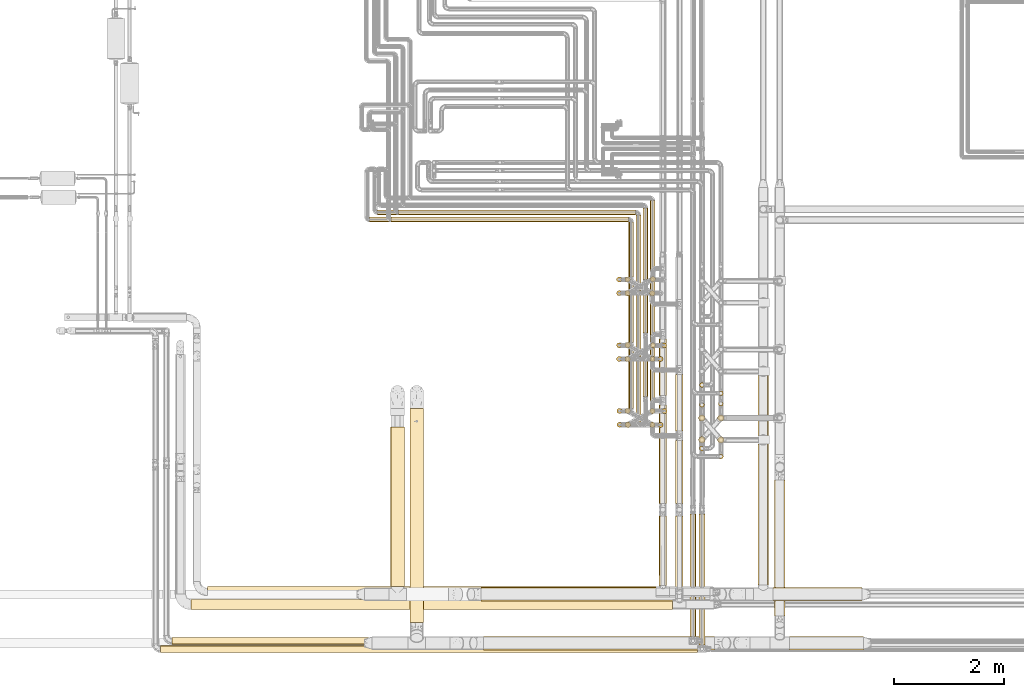
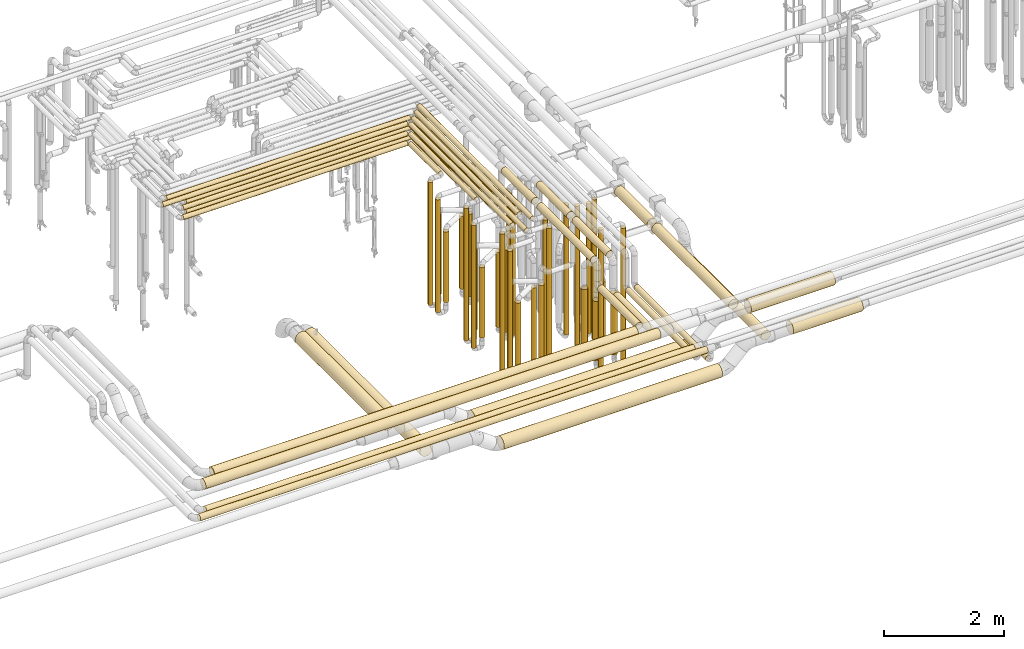
# One storey, part 4 of 827: 71 coverings.
"""IFC2X3 building model written with IfcOpenShell, lengths in millimetres."""

from ifc_helpers import new_model, entity, si_unit, converted_unit, derived_unit, direction, frame, origin, origin_2d_with_axis, place, context, subcontext, project, spatial, circle, extrude, element, save


model = new_model("IFC2X3")

# Units and contexts
model_context = context("Model", 3, precision=0.01, world=origin(), true_north=direction((6.12303176911189e-17, 1.0)))
body_context = subcontext(model_context, "Body", "Model", "MODEL_VIEW")
ifc_project = project(units=[si_unit("LENGTHUNIT", "METRE", prefix="MILLI"), si_unit("AREAUNIT", "SQUARE_METRE"), si_unit("VOLUMEUNIT", "CUBIC_METRE"), converted_unit("PLANEANGLEUNIT", "DEGREE", entity("IfcRatioMeasure", 0.0174532925199433), si_unit("PLANEANGLEUNIT", "RADIAN"), dimensions=[0, 0, 0, 0, 0, 0, 0]), si_unit("MASSUNIT", "GRAM", prefix="KILO"), derived_unit("MASSDENSITYUNIT", [(si_unit("MASSUNIT", "GRAM", prefix="KILO"), 1), (si_unit("LENGTHUNIT", "METRE"), -3)]), derived_unit("MOMENTOFINERTIAUNIT", [(si_unit("LENGTHUNIT", "METRE"), 4)]), si_unit("TIMEUNIT", "SECOND"), si_unit("FREQUENCYUNIT", "HERTZ"), si_unit("THERMODYNAMICTEMPERATUREUNIT", "DEGREE_CELSIUS"), derived_unit("THERMALTRANSMITTANCEUNIT", [(si_unit("MASSUNIT", "GRAM", prefix="KILO"), 1), (si_unit("THERMODYNAMICTEMPERATUREUNIT", "KELVIN"), -1), (si_unit("TIMEUNIT", "SECOND"), -3)]), derived_unit("VOLUMETRICFLOWRATEUNIT", [(si_unit("LENGTHUNIT", "METRE"), 3), (si_unit("TIMEUNIT", "SECOND"), -1)]), derived_unit("MASSFLOWRATEUNIT", [(si_unit("MASSUNIT", "GRAM", prefix="KILO"), 1), (si_unit("TIMEUNIT", "SECOND"), -1)]), derived_unit("ROTATIONALFREQUENCYUNIT", [(si_unit("TIMEUNIT", "SECOND"), -1)]), si_unit("ELECTRICCURRENTUNIT", "AMPERE"), si_unit("ELECTRICVOLTAGEUNIT", "VOLT"), si_unit("POWERUNIT", "WATT"), si_unit("FORCEUNIT", "NEWTON", prefix="KILO"), si_unit("ILLUMINANCEUNIT", "LUX"), si_unit("LUMINOUSFLUXUNIT", "LUMEN"), si_unit("LUMINOUSINTENSITYUNIT", "CANDELA"), derived_unit("USERDEFINED", [(si_unit("MASSUNIT", "GRAM", prefix="KILO"), -1), (si_unit("LENGTHUNIT", "METRE"), -2), (si_unit("TIMEUNIT", "SECOND"), 3), (si_unit("LUMINOUSFLUXUNIT", "LUMEN"), 1)]), derived_unit("LINEARVELOCITYUNIT", [(si_unit("LENGTHUNIT", "METRE"), 1), (si_unit("TIMEUNIT", "SECOND"), -1)]), si_unit("PRESSUREUNIT", "PASCAL"), derived_unit("USERDEFINED", [(si_unit("LENGTHUNIT", "METRE"), -2), (si_unit("MASSUNIT", "GRAM", prefix="KILO"), 1), (si_unit("TIMEUNIT", "SECOND"), -2)]), derived_unit("LINEARFORCEUNIT", [(si_unit("MASSUNIT", "GRAM", prefix="KILO"), 1), (si_unit("LENGTHUNIT", "METRE"), 1), (si_unit("TIMEUNIT", "SECOND"), -2), (si_unit("LENGTHUNIT", "METRE"), -1)]), derived_unit("PLANARFORCEUNIT", [(si_unit("MASSUNIT", "GRAM", prefix="KILO"), 1), (si_unit("LENGTHUNIT", "METRE"), 1), (si_unit("TIMEUNIT", "SECOND"), -2), (si_unit("LENGTHUNIT", "METRE"), -2)])], contexts=[model_context])

# Site, building, storey
site_placement = place(None, origin())
site = spatial("IfcSite", under=ifc_project, at=site_placement, CompositionType="ELEMENT")
building_placement = place(site_placement, origin())
building = spatial("IfcBuilding", under=site, at=building_placement, CompositionType="ELEMENT")
storey_placement = place(building_placement, frame((0.0, 0.0, 28200.0)))
storey = spatial("IfcBuildingStorey", under=building, at=storey_placement, Name="08", CompositionType="ELEMENT", Elevation=28200.0)

# Coverings
covering_1_placement = place(storey_placement, frame((35072.29, 11508.46, 448.0)))
element("IfcCovering", 1, at=covering_1_placement, inside=storey, Name=":ADSK_", ObjectType=":ADSK_", PredefinedType="INSULATION", context=body_context, shape_type="SweptSolid", body=[
    extrude(circle(Radius=46.15, at=origin_2d_with_axis()), frame((47.75, 47.75, 0.0), z_axis=(0.0, 0.0, 1.0), x_axis=(0.0, -1.0, 0.0)), (0.0, 0.0, 1.0), 2504.00000000002),
])
covering_2_placement = place(storey_placement, frame((35895.3, 11758.46, 448.0)))
element("IfcCovering", 2, at=covering_2_placement, inside=storey, Name=":ADSK_", ObjectType=":ADSK_", PredefinedType="INSULATION", context=body_context, shape_type="SweptSolid", body=[
    extrude(circle(Radius=46.15, at=origin_2d_with_axis()), frame((47.75, 47.75, 0.0)), (0.0, 0.0, 1.0), 2704.00000000003),
])
covering_3_placement = place(storey_placement, frame((35077.29, 10309.34, 448.0)))
element("IfcCovering", 3, at=covering_3_placement, inside=storey, Name=":ADSK_", ObjectType=":ADSK_", PredefinedType="INSULATION", context=body_context, shape_type="SweptSolid", body=[
    extrude(circle(Radius=46.15, at=origin_2d_with_axis()), frame((47.75, 47.75, 0.0), z_axis=(0.0, 0.0, 1.0), x_axis=(0.0, -1.0, 0.0)), (0.0, 0.0, 1.0), 2704.00000000001),
])
covering_4_placement = place(storey_placement, frame((35900.3, 10558.46, 448.0)))
element("IfcCovering", 4, at=covering_4_placement, inside=storey, Name=":ADSK_", ObjectType=":ADSK_", PredefinedType="INSULATION", context=body_context, shape_type="SweptSolid", body=[
    extrude(circle(Radius=46.15, at=origin_2d_with_axis()), frame((47.75, 47.75, 0.0), z_axis=(0.0, 0.0, 1.0), x_axis=(-1.0, 0.0, 0.0)), (0.0, 0.0, 1.0), 2904.00000000001),
])
covering_5_placement = place(storey_placement, frame((35847.22, 8921.39, 3479.16)))
element("IfcCovering", 5, at=covering_5_placement, inside=storey, Name=":ADSK_", ObjectType=":ADSK_", PredefinedType="INSULATION", context=body_context, shape_type="SweptSolid", body=[
    extrude(circle(Radius=69.25, at=origin_2d_with_axis()), frame((70.85, 0.0, 70.85), z_axis=(0.0, 1.0, -9.11558874934062e-08), x_axis=(1.0, 0.0, 0.0)), (0.0, 0.0, 1.0), 1798.81487069227),
])
covering_6_placement = place(storey_placement, frame((35847.2, 7422.68, 3029.15)))
element("IfcCovering", 6, at=covering_6_placement, inside=storey, Name=":ADSK_", ObjectType=":ADSK_", PredefinedType="INSULATION", context=body_context, shape_type="SweptSolid", body=[
    extrude(circle(Radius=69.25, at=origin_2d_with_axis()), frame((70.85, 1270.71, 70.85), z_axis=(0.000807635041357438, -0.999999673862767, 0.0), x_axis=(0.999999673862767, 0.000807635041357438, 0.0)), (0.0, 0.0, 1.0), 1270.65564093337),
])
covering_7_placement = place(storey_placement, frame((35682.29, 11854.2, 3152.25)))
element("IfcCovering", 7, at=covering_7_placement, inside=storey, Name=":ADSK_", ObjectType=":ADSK_", PredefinedType="INSULATION", context=body_context, shape_type="SweptSolid", body=[
    extrude(circle(Radius=46.15, at=origin_2d_with_axis()), frame((47.75, 0.0, 47.75), z_axis=(0.0, 1.0, 0.0), x_axis=(-1.0, 0.0, 0.0)), (0.0, 0.0, 1.0), 2587.79707398043),
])
covering_8_placement = place(storey_placement, frame((35552.35, 12031.2, 3152.25)))
element("IfcCovering", 8, at=covering_8_placement, inside=storey, Name=":ADSK_", ObjectType=":ADSK_", PredefinedType="INSULATION", context=body_context, shape_type="SweptSolid", body=[
    extrude(circle(Radius=46.15, at=origin_2d_with_axis()), frame((47.75, 0.0, 47.75), z_axis=(0.0, 1.0, 0.0), x_axis=(1.0, 0.0, 0.0)), (0.0, 0.0, 1.0), 2280.79727405418),
])
covering_9_placement = place(storey_placement, frame((35682.29, 10654.2, 3352.25)))
element("IfcCovering", 9, at=covering_9_placement, inside=storey, Name=":ADSK_", ObjectType=":ADSK_", PredefinedType="INSULATION", context=body_context, shape_type="SweptSolid", body=[
    extrude(circle(Radius=46.15, at=origin_2d_with_axis()), frame((47.75, 0.0, 47.75), z_axis=(0.0, 1.0, 0.0), x_axis=(1.0, 0.0, 0.0)), (0.0, 0.0, 1.0), 3787.79707398042),
])
covering_10_placement = place(storey_placement, frame((35552.35, 10876.38, 3352.25)))
element("IfcCovering", 10, at=covering_10_placement, inside=storey, Name=":ADSK_", ObjectType=":ADSK_", PredefinedType="INSULATION", context=body_context, shape_type="SweptSolid", body=[
    extrude(circle(Radius=46.15, at=origin_2d_with_axis()), frame((47.75, 0.0, 47.75), z_axis=(0.0, 1.0, 0.0), x_axis=(1.0, 0.0, 0.0)), (0.0, 0.0, 1.0), 3435.62396825438),
])
covering_11_placement = place(storey_placement, frame((35847.22, 10892.2, 3479.16)))
element("IfcCovering", 11, at=covering_11_placement, inside=storey, Name=":ADSK_", ObjectType=":ADSK_", PredefinedType="INSULATION", context=body_context, shape_type="SweptSolid", body=[
    extrude(circle(Radius=69.25, at=origin_2d_with_axis()), frame((70.85, 0.0, 70.85), z_axis=(0.0, 1.0, -9.11558935474048e-08), x_axis=(1.0, 0.0, 0.0)), (0.0, 0.0, 1.0), 1027.87693556046),
])
covering_12_placement = place(storey_placement, frame((35228.27, 10306.49, 604.0)))
element("IfcCovering", 12, at=covering_12_placement, inside=storey, Name=":ADSK_", ObjectType=":ADSK_", PredefinedType="INSULATION", context=body_context, shape_type="SweptSolid", body=[
    extrude(circle(Radius=49.0, at=origin_2d_with_axis()), frame((50.6, 50.6, 0.0), z_axis=(0.0, 1.97430995600526e-06, 1.0), x_axis=(-1.0, 0.0, 0.0)), (0.0, 0.0, 1.0), 1439.00000000281),
])
covering_13_placement = place(storey_placement, frame((35677.45, 10555.61, 559.0)))
element("IfcCovering", 13, at=covering_13_placement, inside=storey, Name=":ADSK_", ObjectType=":ADSK_", PredefinedType="INSULATION", context=body_context, shape_type="SweptSolid", body=[
    extrude(circle(Radius=49.0, at=origin_2d_with_axis()), frame((50.6, 50.6, 0.0), z_axis=(0.0, 0.0, 1.0), x_axis=(-1.0, 0.0, 0.0)), (0.0, 0.0, 1.0), 1484.0),
])
covering_14_placement = place(storey_placement, frame((35224.44, 11505.05, 603.98)))
element("IfcCovering", 14, at=covering_14_placement, inside=storey, Name=":ADSK_", ObjectType=":ADSK_", PredefinedType="INSULATION", context=body_context, shape_type="SweptSolid", body=[
    extrude(circle(Radius=49.0, at=origin_2d_with_axis()), frame((50.6, 51.21, 0.02), z_axis=(0.0, -0.000429537009763512, 0.999999907748974), x_axis=(1.0, 0.0, 0.0)), (0.0, 0.0, 1.0), 1438.97359676792),
])
covering_15_placement = place(storey_placement, frame((35686.26, 11755.07, 511.98)))
element("IfcCovering", 15, at=covering_15_placement, inside=storey, Name=":ADSK_", ObjectType=":ADSK_", PredefinedType="INSULATION", context=body_context, shape_type="SweptSolid", body=[
    extrude(circle(Radius=49.0, at=origin_2d_with_axis()), frame((50.6, 51.09, 0.02), z_axis=(0.0, -0.000321811119658756, 0.9999999482188), x_axis=(1.0, 0.0, 0.0)), (0.0, 0.0, 1.0), 1531.00008703173),
])
covering_16_placement = place(storey_placement, frame((27310.33, 6983.4, 3003.4)))
element("IfcCovering", 16, at=covering_16_placement, inside=storey, Name=":ADSK_", ObjectType=":ADSK_", PredefinedType="INSULATION", context=body_context, shape_type="SweptSolid", body=[
    extrude(circle(Radius=95.0, at=origin_2d_with_axis()), frame((0.0, 96.6, 96.6), z_axis=(1.0, 0.0, 0.0), x_axis=(0.0, -0.707106781186544, -0.707106781186551)), (0.0, 0.0, 1.0), 8785.70070250989),
])
covering_17_placement = place(storey_placement, frame((31094.52, 14182.26, 3152.25)))
element("IfcCovering", 17, at=covering_17_placement, inside=storey, Name=":ADSK_", ObjectType=":ADSK_", PredefinedType="INSULATION", context=body_context, shape_type="SweptSolid", body=[
    extrude(circle(Radius=46.15, at=origin_2d_with_axis()), frame((0.0, 47.75, 47.75), z_axis=(1.0, 0.0, 0.0), x_axis=(0.0, -1.0, 0.0)), (0.0, 0.0, 1.0), 4327.51165000006),
])
covering_18_placement = place(storey_placement, frame((30964.52, 14052.26, 3152.25)))
element("IfcCovering", 18, at=covering_18_placement, inside=storey, Name=":ADSK_", ObjectType=":ADSK_", PredefinedType="INSULATION", context=body_context, shape_type="SweptSolid", body=[
    extrude(circle(Radius=46.15, at=origin_2d_with_axis()), frame((0.0, 47.75, 47.75), z_axis=(1.0, 0.0, 0.0), x_axis=(0.0, -1.0, 0.0)), (0.0, 0.0, 1.0), 4327.51165000005),
])
covering_19_placement = place(storey_placement, frame((30718.34, 14182.26, 3352.25)))
element("IfcCovering", 19, at=covering_19_placement, inside=storey, Name=":ADSK_", ObjectType=":ADSK_", PredefinedType="INSULATION", context=body_context, shape_type="SweptSolid", body=[
    extrude(circle(Radius=46.15, at=origin_2d_with_axis()), frame((0.0, 47.75, 47.75), z_axis=(1.0, 0.0, 0.0), x_axis=(0.0, -1.0, 0.0)), (0.0, 0.0, 1.0), 4703.69587000002),
])
covering_20_placement = place(storey_placement, frame((30569.52, 14052.26, 3352.25)))
element("IfcCovering", 20, at=covering_20_placement, inside=storey, Name=":ADSK_", ObjectType=":ADSK_", PredefinedType="INSULATION", context=body_context, shape_type="SweptSolid", body=[
    extrude(circle(Radius=46.15, at=origin_2d_with_axis()), frame((0.0, 47.75, 47.75), z_axis=(1.0, 0.0, 0.0), x_axis=(0.0, -1.0, 0.0)), (0.0, 0.0, 1.0), 4722.51165000002),
])
covering_21_placement = place(storey_placement, frame((35072.29, 11758.46, 448.0)))
element("IfcCovering", 21, at=covering_21_placement, inside=storey, Name=":ADSK_", ObjectType=":ADSK_", PredefinedType="INSULATION", context=body_context, shape_type="SweptSolid", body=[
    extrude(circle(Radius=46.15, at=origin_2d_with_axis()), frame((47.75, 47.75, 0.0), z_axis=(0.0, 0.0, 1.0), x_axis=(0.0, -1.0, 0.0)), (0.0, 0.0, 1.0), 2704.00000000002),
])
covering_22_placement = place(storey_placement, frame((35826.04, 11508.42, 448.0)))
element("IfcCovering", 22, at=covering_22_placement, inside=storey, Name=":ADSK_", ObjectType=":ADSK_", PredefinedType="INSULATION", context=body_context, shape_type="SweptSolid", body=[
    extrude(circle(Radius=46.15, at=origin_2d_with_axis()), frame((47.75, 47.75, 0.0), z_axis=(0.0, 0.0, 1.0), x_axis=(-1.0, 0.0, 0.0)), (0.0, 0.0, 1.0), 2704.00000000003),
])
covering_23_placement = place(storey_placement, frame((35077.29, 10561.4, 448.0)))
element("IfcCovering", 23, at=covering_23_placement, inside=storey, Name=":ADSK_", ObjectType=":ADSK_", PredefinedType="INSULATION", context=body_context, shape_type="SweptSolid", body=[
    extrude(circle(Radius=46.15, at=origin_2d_with_axis()), frame((47.75, 47.75, 0.0), z_axis=(0.0, 0.0, 1.0), x_axis=(0.0, -1.0, 0.0)), (0.0, 0.0, 1.0), 2904.0),
])
covering_24_placement = place(storey_placement, frame((35831.04, 10308.42, 448.0)))
element("IfcCovering", 24, at=covering_24_placement, inside=storey, Name=":ADSK_", ObjectType=":ADSK_", PredefinedType="INSULATION", context=body_context, shape_type="SweptSolid", body=[
    extrude(circle(Radius=46.15, at=origin_2d_with_axis()), frame((47.75, 47.75, 0.0)), (0.0, 0.0, 1.0), 2904.00000000001),
])
covering_25_placement = place(storey_placement, frame((36149.19, 8921.39, 3479.16)))
element("IfcCovering", 25, at=covering_25_placement, inside=storey, Name=":ADSK_", ObjectType=":ADSK_", PredefinedType="INSULATION", context=body_context, shape_type="SweptSolid", body=[
    extrude(circle(Radius=69.25, at=origin_2d_with_axis()), frame((70.85, 0.0, 70.85), z_axis=(0.0, 1.0, -8.51254598960259e-08), x_axis=(1.0, 0.0, 0.0)), (0.0, 0.0, 1.0), 1148.81413940413),
])
covering_26_placement = place(storey_placement, frame((36149.19, 7376.95, 2779.15)))
element("IfcCovering", 26, at=covering_26_placement, inside=storey, Name=":ADSK_", ObjectType=":ADSK_", PredefinedType="INSULATION", context=body_context, shape_type="SweptSolid", body=[
    extrude(circle(Radius=69.25, at=origin_2d_with_axis()), frame((70.85, 0.0, 70.85), z_axis=(0.0, 1.0, 0.0), x_axis=(1.0, 0.0, 0.0)), (0.0, 0.0, 1.0), 1316.44024231723),
])
covering_27_placement = place(storey_placement, frame((35292.29, 11854.2, 3152.25)))
element("IfcCovering", 27, at=covering_27_placement, inside=storey, Name=":ADSK_", ObjectType=":ADSK_", PredefinedType="INSULATION", context=body_context, shape_type="SweptSolid", body=[
    extrude(circle(Radius=46.15, at=origin_2d_with_axis()), frame((47.75, 0.0, 47.75), z_axis=(0.0, 1.0, 0.0), x_axis=(-1.0, 0.0, 0.0)), (0.0, 0.0, 1.0), 2197.79707405417),
])
covering_28_placement = place(storey_placement, frame((35422.29, 11604.17, 3152.25)))
element("IfcCovering", 28, at=covering_28_placement, inside=storey, Name=":ADSK_", ObjectType=":ADSK_", PredefinedType="INSULATION", context=body_context, shape_type="SweptSolid", body=[
    extrude(circle(Radius=46.15, at=origin_2d_with_axis()), frame((47.75, 0.0, 47.75), z_axis=(0.0, 1.0, 0.0), x_axis=(-1.0, 0.0, 0.0)), (0.0, 0.0, 1.0), 2577.83166077068),
])
covering_29_placement = place(storey_placement, frame((35292.29, 10657.14, 3352.25)))
element("IfcCovering", 29, at=covering_29_placement, inside=storey, Name=":ADSK_", ObjectType=":ADSK_", PredefinedType="INSULATION", context=body_context, shape_type="SweptSolid", body=[
    extrude(circle(Radius=46.15, at=origin_2d_with_axis()), frame((47.75, 0.0, 47.75), z_axis=(0.0, 1.0, 0.0), x_axis=(-1.0, 0.0, 0.0)), (0.0, 0.0, 1.0), 3394.85688841738),
])
covering_30_placement = place(storey_placement, frame((35422.29, 10404.17, 3352.25)))
element("IfcCovering", 30, at=covering_30_placement, inside=storey, Name=":ADSK_", ObjectType=":ADSK_", PredefinedType="INSULATION", context=body_context, shape_type="SweptSolid", body=[
    extrude(circle(Radius=46.15, at=origin_2d_with_axis()), frame((47.75, 0.0, 47.75), z_axis=(0.0, 1.0, 0.0), x_axis=(1.0, 0.0, 0.0)), (0.0, 0.0, 1.0), 3777.83166077068),
])
covering_31_placement = place(storey_placement, frame((36149.19, 10242.2, 3479.15)))
element("IfcCovering", 31, at=covering_31_placement, inside=storey, Name=":ADSK_", ObjectType=":ADSK_", PredefinedType="INSULATION", context=body_context, shape_type="SweptSolid", body=[
    extrude(circle(Radius=69.25, at=origin_2d_with_axis()), frame((70.85, 0.0, 70.85), z_axis=(0.0, 1.0, -9.11558977614012e-08), x_axis=(1.0, 0.0, 0.0)), (0.0, 0.0, 1.0), 1027.87693556044),
])
covering_32_placement = place(storey_placement, frame((35677.45, 10305.57, 559.0)))
element("IfcCovering", 32, at=covering_32_placement, inside=storey, Name=":ADSK_", ObjectType=":ADSK_", PredefinedType="INSULATION", context=body_context, shape_type="SweptSolid", body=[
    extrude(circle(Radius=49.0, at=origin_2d_with_axis()), frame((50.6, 50.6, 0.0), z_axis=(0.0, 0.0, 1.0), x_axis=(-1.0, 0.0, 0.0)), (0.0, 0.0, 1.0), 1688.99999999998),
])
covering_33_placement = place(storey_placement, frame((35226.14, 10558.53, 604.0)))
element("IfcCovering", 33, at=covering_33_placement, inside=storey, Name=":ADSK_", ObjectType=":ADSK_", PredefinedType="INSULATION", context=body_context, shape_type="SweptSolid", body=[
    extrude(circle(Radius=49.0, at=origin_2d_with_axis()), frame((50.6, 50.61, 0.0), z_axis=(0.0, -1.10407019482887e-05, 1.0), x_axis=(-1.0, 0.0, 0.0)), (0.0, 0.0, 1.0), 1644.00000010021),
])
covering_34_placement = place(storey_placement, frame((35678.19, 11503.87, 558.95)))
element("IfcCovering", 34, at=covering_34_placement, inside=storey, Name=":ADSK_", ObjectType=":ADSK_", PredefinedType="INSULATION", context=body_context, shape_type="SweptSolid", body=[
    extrude(circle(Radius=49.0, at=origin_2d_with_axis()), frame((50.6, 52.3, 0.05), z_axis=(0.0, -0.00101019809551677, 0.999999489749774), x_axis=(0.0, -0.999999489749774, -0.00101019809551677)), (0.0, 0.0, 1.0), 1689.00086181307),
])
covering_35_placement = place(storey_placement, frame((35225.64, 11757.53, 604.0)))
element("IfcCovering", 35, at=covering_35_placement, inside=storey, Name=":ADSK_", ObjectType=":ADSK_", PredefinedType="INSULATION", context=body_context, shape_type="SweptSolid", body=[
    extrude(circle(Radius=49.0, at=origin_2d_with_axis()), frame((50.6, 50.6, 0.0), z_axis=(0.0, 0.0, 1.0), x_axis=(-1.0, 0.0, 0.0)), (0.0, 0.0, 1.0), 1644.0),
])
covering_36_placement = place(storey_placement, frame((35552.35, 13004.17, 2952.25)))
element("IfcCovering", 36, at=covering_36_placement, inside=storey, Name=":ADSK_", ObjectType=":ADSK_", PredefinedType="INSULATION", context=body_context, shape_type="SweptSolid", body=[
    extrude(circle(Radius=46.15, at=origin_2d_with_axis()), frame((47.75, 0.0, 47.75), z_axis=(0.0, 1.0, 0.0), x_axis=(1.0, 0.0, 0.0)), (0.0, 0.0, 1.0), 1307.82580405416),
])
covering_37_placement = place(storey_placement, frame((35072.29, 12708.46, 448.0)))
element("IfcCovering", 37, at=covering_37_placement, inside=storey, Name=":ADSK_", ObjectType=":ADSK_", PredefinedType="INSULATION", context=body_context, shape_type="SweptSolid", body=[
    extrude(circle(Radius=46.15, at=origin_2d_with_axis()), frame((47.75, 47.75, 0.0), z_axis=(0.0, 0.0, 1.0), x_axis=(0.0, 1.0, 0.0)), (0.0, 0.0, 1.0), 2303.60885615262),
])
covering_38_placement = place(storey_placement, frame((31094.52, 14182.26, 2952.25)))
element("IfcCovering", 38, at=covering_38_placement, inside=storey, Name=":ADSK_", ObjectType=":ADSK_", PredefinedType="INSULATION", context=body_context, shape_type="SweptSolid", body=[
    extrude(circle(Radius=46.15, at=origin_2d_with_axis()), frame((0.0, 47.75, 47.75), z_axis=(1.0, 0.0, 0.0), x_axis=(0.0, 1.0, 0.0)), (0.0, 0.0, 1.0), 4327.51165000003),
])
covering_39_placement = place(storey_placement, frame((35422.29, 12804.17, 2952.25)))
element("IfcCovering", 39, at=covering_39_placement, inside=storey, Name=":ADSK_", ObjectType=":ADSK_", PredefinedType="INSULATION", context=body_context, shape_type="SweptSolid", body=[
    extrude(circle(Radius=46.15, at=origin_2d_with_axis()), frame((47.75, 0.0, 47.75), z_axis=(0.0, 1.0, 0.0), x_axis=(1.0, 0.0, 0.0)), (0.0, 0.0, 1.0), 1377.83166077068),
])
covering_40_placement = place(storey_placement, frame((35682.29, 13054.2, 2952.25)))
element("IfcCovering", 40, at=covering_40_placement, inside=storey, Name=":ADSK_", ObjectType=":ADSK_", PredefinedType="INSULATION", context=body_context, shape_type="SweptSolid", body=[
    extrude(circle(Radius=46.15, at=origin_2d_with_axis()), frame((47.75, 0.0, 47.75), z_axis=(0.0, 1.0, 0.0), x_axis=(1.0, 0.0, 0.0)), (0.0, 0.0, 1.0), 1387.79707398041),
])
covering_41_placement = place(storey_placement, frame((30964.52, 14052.26, 2952.25)))
element("IfcCovering", 41, at=covering_41_placement, inside=storey, Name=":ADSK_", ObjectType=":ADSK_", PredefinedType="INSULATION", context=body_context, shape_type="SweptSolid", body=[
    extrude(circle(Radius=46.15, at=origin_2d_with_axis()), frame((0.0, 47.75, 47.75), z_axis=(1.0, 0.0, 0.0), x_axis=(0.0, 1.0, 0.0)), (0.0, 0.0, 1.0), 4327.51165000003),
])
covering_42_placement = place(storey_placement, frame((35292.29, 13054.2, 2952.25)))
element("IfcCovering", 42, at=covering_42_placement, inside=storey, Name=":ADSK_", ObjectType=":ADSK_", PredefinedType="INSULATION", context=body_context, shape_type="SweptSolid", body=[
    extrude(circle(Radius=46.15, at=origin_2d_with_axis()), frame((47.75, 0.0, 47.75), z_axis=(0.0, 1.0, 0.0), x_axis=(1.0, 0.0, 0.0)), (0.0, 0.0, 1.0), 997.797074054168),
])
covering_43_placement = place(storey_placement, frame((35072.29, 12958.46, 448.0)))
element("IfcCovering", 43, at=covering_43_placement, inside=storey, Name=":ADSK_", ObjectType=":ADSK_", PredefinedType="INSULATION", context=body_context, shape_type="SweptSolid", body=[
    extrude(circle(Radius=46.15, at=origin_2d_with_axis()), frame((47.75, 47.75, 0.0), z_axis=(0.0, 0.0, 1.0), x_axis=(0.0, 1.0, 0.0)), (0.0, 0.0, 1.0), 2504.0),
])
covering_44_placement = place(storey_placement, frame((35683.54, 12960.08, 559.0)))
element("IfcCovering", 44, at=covering_44_placement, inside=storey, Name=":ADSK_", ObjectType=":ADSK_", PredefinedType="INSULATION", context=body_context, shape_type="SweptSolid", body=[
    extrude(circle(Radius=49.0, at=origin_2d_with_axis()), frame((50.6, 50.6, 0.0), z_axis=(0.0, 0.0, 1.0), x_axis=(-1.0, 0.0, 0.0)), (0.0, 0.0, 1.0), 1484.0),
])
covering_45_placement = place(storey_placement, frame((35224.75, 12955.94, 604.0)))
element("IfcCovering", 45, at=covering_45_placement, inside=storey, Name=":ADSK_", ObjectType=":ADSK_", PredefinedType="INSULATION", context=body_context, shape_type="SweptSolid", body=[
    extrude(circle(Radius=49.0, at=origin_2d_with_axis()), frame((50.6, 50.6, 0.0), z_axis=(0.0, 0.0, 1.0), x_axis=(-1.0, 0.0, 0.0)), (0.0, 0.0, 1.0), 1644.0),
])
covering_46_placement = place(storey_placement, frame((35674.44, 12703.87, 559.0)))
element("IfcCovering", 46, at=covering_46_placement, inside=storey, Name=":ADSK_", ObjectType=":ADSK_", PredefinedType="INSULATION", context=body_context, shape_type="SweptSolid", body=[
    extrude(circle(Radius=49.0, at=origin_2d_with_axis()), frame((50.6, 50.6, 0.0), z_axis=(0.0, 0.0, 1.0), x_axis=(-1.0, 0.0, 0.0)), (0.0, 0.0, 1.0), 1688.99999999999),
])
covering_47_placement = place(storey_placement, frame((35222.31, 12704.26, 604.0)))
element("IfcCovering", 47, at=covering_47_placement, inside=storey, Name=":ADSK_", ObjectType=":ADSK_", PredefinedType="INSULATION", context=body_context, shape_type="SweptSolid", body=[
    extrude(circle(Radius=49.0, at=origin_2d_with_axis()), frame((50.6, 50.6, 0.0), z_axis=(0.0, 0.0, 1.0), x_axis=(-1.0, 0.0, 0.0)), (0.0, 0.0, 1.0), 1439.0),
])
covering_48_placement = place(storey_placement, frame((37926.3, 7140.11, 2773.77)))
element("IfcCovering", 48, at=covering_48_placement, inside=storey, Name=":ADSK_", ObjectType=":ADSK_", PredefinedType="INSULATION", context=body_context, shape_type="SweptSolid", body=[
    extrude(circle(Radius=124.5, at=origin_2d_with_axis()), frame((0.0, 126.1, 126.1), z_axis=(1.0, 0.0, 4.27481930386784e-06), x_axis=(0.0, 1.0, 0.0)), (0.0, 0.0, 1.0), 1624.74567570153),
])
covering_49_placement = place(storey_placement, frame((37652.2, 7434.2, 2803.81)))
element("IfcCovering", 49, at=covering_49_placement, inside=storey, Name=":ADSK_", ObjectType=":ADSK_", PredefinedType="INSULATION", context=body_context, shape_type="SweptSolid", body=[
    extrude(circle(Radius=94.5, at=origin_2d_with_axis()), frame((96.1, 0.0, 96.1), z_axis=(0.0, 1.0, -7.18992412660133e-07), x_axis=(-1.0, 0.0, 0.0)), (0.0, 0.0, 1.0), 2568.50011294233),
])
covering_50_placement = place(storey_placement, frame((36928.44, 10884.58, 476.0)))
element("IfcCovering", 50, at=covering_50_placement, inside=storey, Name=":ADSK_", ObjectType=":ADSK_", PredefinedType="INSULATION", context=body_context, shape_type="SweptSolid", body=[
    extrude(circle(Radius=45.0, at=origin_2d_with_axis()), frame((46.6, 46.6, 0.0), z_axis=(0.0, 0.0, 1.0), x_axis=(-1.0, 0.0, 0.0)), (3.39879591138015e-09, 0.0, 1.0), 2647.99999099998),
])
covering_51_placement = place(storey_placement, frame((36928.44, 9734.43, 476.0)))
element("IfcCovering", 51, at=covering_51_placement, inside=storey, Name=":ADSK_", ObjectType=":ADSK_", PredefinedType="INSULATION", context=body_context, shape_type="SweptSolid", body=[
    extrude(circle(Radius=45.0, at=origin_2d_with_axis()), frame((46.6, 46.6, 0.0), z_axis=(0.0, 0.0, 1.0), x_axis=(-1.0, 0.0, 0.0)), (3.16011039558362e-09, 0.0, 1.0), 2847.99999099998),
])
covering_52_placement = place(storey_placement, frame((36583.05, 10673.13, 476.0)))
element("IfcCovering", 52, at=covering_52_placement, inside=storey, Name=":ADSK_", ObjectType=":ADSK_", PredefinedType="INSULATION", context=body_context, shape_type="SweptSolid", body=[
    extrude(circle(Radius=45.0, at=origin_2d_with_axis()), frame((46.6, 46.6, 0.0)), (0.0, 0.0, 1.0), 2847.99999999999),
])
covering_53_placement = place(storey_placement, frame((36568.8, 10419.36, 565.0)))
element("IfcCovering", 53, at=covering_53_placement, inside=storey, Name=":ADSK_", ObjectType=":ADSK_", PredefinedType="INSULATION", context=body_context, shape_type="SweptSolid", body=[
    extrude(circle(Radius=59.25, at=origin_2d_with_axis()), frame((60.85, 60.85, 0.0), z_axis=(0.0, 0.0, 1.0), x_axis=(-1.0, 0.0, 0.0)), (0.0, 0.0, 1.0), 1215.99999999998),
])
covering_54_placement = place(storey_placement, frame((36914.19, 10019.36, 565.0)))
element("IfcCovering", 54, at=covering_54_placement, inside=storey, Name=":ADSK_", ObjectType=":ADSK_", PredefinedType="INSULATION", context=body_context, shape_type="SweptSolid", body=[
    extrude(circle(Radius=59.25, at=origin_2d_with_axis()), frame((60.85, 60.85, 0.0), z_axis=(0.0, 0.0, 1.0), x_axis=(0.0, 1.0, 0.0)), (0.0, 0.0, 1.0), 1245.99999099997),
])
covering_55_placement = place(storey_placement, frame((27610.03, 7213.4, 3003.4)))
element("IfcCovering", 55, at=covering_55_placement, inside=storey, Name=":ADSK_", ObjectType=":ADSK_", PredefinedType="INSULATION", context=body_context, shape_type="SweptSolid", body=[
    extrude(circle(Radius=95.0, at=origin_2d_with_axis()), frame((0.0, 96.6, 96.6), z_axis=(1.0, 0.0, 0.0), x_axis=(0.0, -1.0, 0.0)), (0.0, 0.0, 1.0), 8185.03374931238),
])
covering_56_placement = place(storey_placement, frame((26962.64, 6351.97, 3035.4)))
element("IfcCovering", 56, at=covering_56_placement, inside=storey, Name=":ADSK_", ObjectType=":ADSK_", PredefinedType="INSULATION", context=body_context, shape_type="SweptSolid", body=[
    extrude(circle(Radius=63.0, at=origin_2d_with_axis()), frame((0.0, 64.6, 64.6), z_axis=(1.0, 0.0, 0.0), x_axis=(0.0, -1.0, 0.0)), (0.0, 0.0, 1.0), 9430.07864615945),
])
covering_57_placement = place(storey_placement, frame((36412.12, 6492.57, 2793.4)))
element("IfcCovering", 57, at=covering_57_placement, inside=storey, Name=":ADSK_", ObjectType=":ADSK_", PredefinedType="INSULATION", context=body_context, shape_type="SweptSolid", body=[
    extrude(circle(Radius=55.0, at=origin_2d_with_axis()), frame((56.6, 0.0, 56.6), z_axis=(0.0, 1.0, 0.0), x_axis=(-1.0, 0.0, 0.0)), (0.0, 0.0, 1.0), 2238.82114274712),
])
covering_58_placement = place(storey_placement, frame((26758.64, 6201.11, 3035.4)))
element("IfcCovering", 58, at=covering_58_placement, inside=storey, Name=":ADSK_", ObjectType=":ADSK_", PredefinedType="INSULATION", context=body_context, shape_type="SweptSolid", body=[
    extrude(circle(Radius=63.0, at=origin_2d_with_axis()), frame((0.0, 64.6, 64.6), z_axis=(1.0, 0.0, 0.0), x_axis=(0.0, -1.0, 0.0)), (0.0, 0.0, 1.0), 9795.00564256815),
])
covering_59_placement = place(storey_placement, frame((36573.05, 6341.81, 2793.4)))
element("IfcCovering", 59, at=covering_59_placement, inside=storey, Name=":ADSK_", ObjectType=":ADSK_", PredefinedType="INSULATION", context=body_context, shape_type="SweptSolid", body=[
    extrude(circle(Radius=55.0, at=origin_2d_with_axis()), frame((56.6, 0.0, 56.6), z_axis=(0.0, 1.0, 2.8092716982407e-07), x_axis=(-1.0, 0.0, 0.0)), (0.0, 0.0, 1.0), 2389.57772043251),
])
covering_60_placement = place(storey_placement, frame((32603.88, 7140.11, 2373.87)))
element("IfcCovering", 60, at=covering_60_placement, inside=storey, Name=":ADSK_", ObjectType=":ADSK_", PredefinedType="INSULATION", context=body_context, shape_type="SweptSolid", body=[
    extrude(circle(Radius=124.5, at=origin_2d_with_axis()), frame((0.0, 126.1, 126.1), z_axis=(1.0, 0.0, 4.7406801690562e-07), x_axis=(0.0, -1.0, 0.0)), (0.0, 0.0, 1.0), 4174.30145695366),
])
covering_61_placement = place(storey_placement, frame((31303.9, 6749.26, 2423.9)))
element("IfcCovering", 61, at=covering_61_placement, inside=storey, Name=":ADSK_", ObjectType=":ADSK_", PredefinedType="INSULATION", context=body_context, shape_type="SweptSolid", body=[
    extrude(circle(Radius=124.5, at=origin_2d_with_axis()), frame((126.1, 0.0, 126.1), z_axis=(0.0, 1.0, 0.0), x_axis=(-1.0, 0.0, 0.0)), (0.0, 0.0, 1.0), 3900.73593128801),
])
covering_62_placement = place(storey_placement, frame((38226.3, 6248.9, 2773.9)))
element("IfcCovering", 62, at=covering_62_placement, inside=storey, Name=":ADSK_", ObjectType=":ADSK_", PredefinedType="INSULATION", context=body_context, shape_type="SweptSolid", body=[
    extrude(circle(Radius=124.5, at=origin_2d_with_axis()), frame((0.0, 126.1, 126.1), z_axis=(1.0, 0.0, 0.0), x_axis=(0.0, 1.0, 0.0)), (0.0, 0.0, 1.0), 1348.80954210606),
])
covering_63_placement = place(storey_placement, frame((37952.2, 6868.2, 2403.9)))
element("IfcCovering", 63, at=covering_63_placement, inside=storey, Name=":ADSK_", ObjectType=":ADSK_", PredefinedType="INSULATION", context=body_context, shape_type="SweptSolid", body=[
    extrude(circle(Radius=94.5, at=origin_2d_with_axis()), frame((96.1, 0.0, 96.1), z_axis=(0.0, 1.0, 0.0), x_axis=(-1.0, 0.0, 0.0)), (0.0, 0.0, 1.0), 2485.51890325304),
])
covering_64_placement = place(storey_placement, frame((36583.05, 11034.58, 476.0)))
element("IfcCovering", 64, at=covering_64_placement, inside=storey, Name=":ADSK_", ObjectType=":ADSK_", PredefinedType="INSULATION", context=body_context, shape_type="SweptSolid", body=[
    extrude(circle(Radius=45.0, at=origin_2d_with_axis()), frame((46.6, 46.6, 0.0), z_axis=(0.0, 0.0, 1.0), x_axis=(0.0, -1.0, 0.0)), (0.0, 0.0, 1.0), 2647.99999099998),
])
covering_65_placement = place(storey_placement, frame((36928.44, 10693.61, 476.0)))
element("IfcCovering", 65, at=covering_65_placement, inside=storey, Name=":ADSK_", ObjectType=":ADSK_", PredefinedType="INSULATION", context=body_context, shape_type="SweptSolid", body=[
    extrude(circle(Radius=45.0, at=origin_2d_with_axis()), frame((46.6, 46.6, 0.0)), (0.0, 0.0, 1.0), 2848.0),
])
covering_66_placement = place(storey_placement, frame((36914.19, 10419.36, 565.0)))
element("IfcCovering", 66, at=covering_66_placement, inside=storey, Name=":ADSK_", ObjectType=":ADSK_", PredefinedType="INSULATION", context=body_context, shape_type="SweptSolid", body=[
    extrude(circle(Radius=59.25, at=origin_2d_with_axis()), frame((60.85, 60.85, 0.0), z_axis=(0.0, 0.0, 1.0), x_axis=(-1.0, 0.0, 0.0)), (0.0, 0.0, 1.0), 1245.99999999999),
])
covering_67_placement = place(storey_placement, frame((36568.8, 10020.75, 565.0)))
element("IfcCovering", 67, at=covering_67_placement, inside=storey, Name=":ADSK_", ObjectType=":ADSK_", PredefinedType="INSULATION", context=body_context, shape_type="SweptSolid", body=[
    extrude(circle(Radius=59.25, at=origin_2d_with_axis()), frame((60.85, 60.85, 0.0), z_axis=(0.0, 0.0, 1.0), x_axis=(0.0, -1.0, 0.0)), (0.0, 0.0, 1.0), 1215.99999099995),
])
covering_68_placement = place(storey_placement, frame((36583.05, 9879.58, 476.0)))
element("IfcCovering", 68, at=covering_68_placement, inside=storey, Name=":ADSK_", ObjectType=":ADSK_", PredefinedType="INSULATION", context=body_context, shape_type="SweptSolid", body=[
    extrude(circle(Radius=45.0, at=origin_2d_with_axis()), frame((46.6, 46.6, 0.0), z_axis=(0.0, 0.0, 1.0), x_axis=(0.0, -1.0, 0.0)), (0.0, 0.0, 1.0), 2847.99999099997),
])
covering_69_placement = place(storey_placement, frame((32643.13, 6248.9, 2373.9)))
element("IfcCovering", 69, at=covering_69_placement, inside=storey, Name=":ADSK_", ObjectType=":ADSK_", PredefinedType="INSULATION", context=body_context, shape_type="SweptSolid", body=[
    extrude(circle(Radius=124.5, at=origin_2d_with_axis()), frame((0.0, 126.1, 126.1), z_axis=(1.0, 0.0, 0.0), x_axis=(0.0, 1.0, 0.0)), (0.0, 0.0, 1.0), 4214.83070096532),
])
covering_70_placement = place(storey_placement, frame((37652.2, 10157.7, 2803.81)))
element("IfcCovering", 70, at=covering_70_placement, inside=storey, Name=":ADSK_", ObjectType=":ADSK_", PredefinedType="INSULATION", context=body_context, shape_type="SweptSolid", body=[
    extrude(circle(Radius=94.5, at=origin_2d_with_axis()), frame((96.1, 0.0, 96.1), z_axis=(0.0, 1.0, -7.18992411449206e-07), x_axis=(-1.0, 0.0, 0.0)), (0.0, 0.0, 1.0), 1095.00000000033),
])
covering_71_placement = place(storey_placement, frame((30953.9, 7406.2, 2673.9)))
element("IfcCovering", 71, at=covering_71_placement, inside=storey, Name=":ADSK_", ObjectType=":ADSK_", PredefinedType="INSULATION", context=body_context, shape_type="SweptSolid", body=[
    extrude(circle(Radius=124.5, at=origin_2d_with_axis()), frame((126.1, 0.0, 126.1), z_axis=(0.0, 1.0, 0.0), x_axis=(1.0, 0.0, 0.0)), (0.0, 0.0, 1.0), 2913.62254577972),
])

save(model, "model.ifc")
